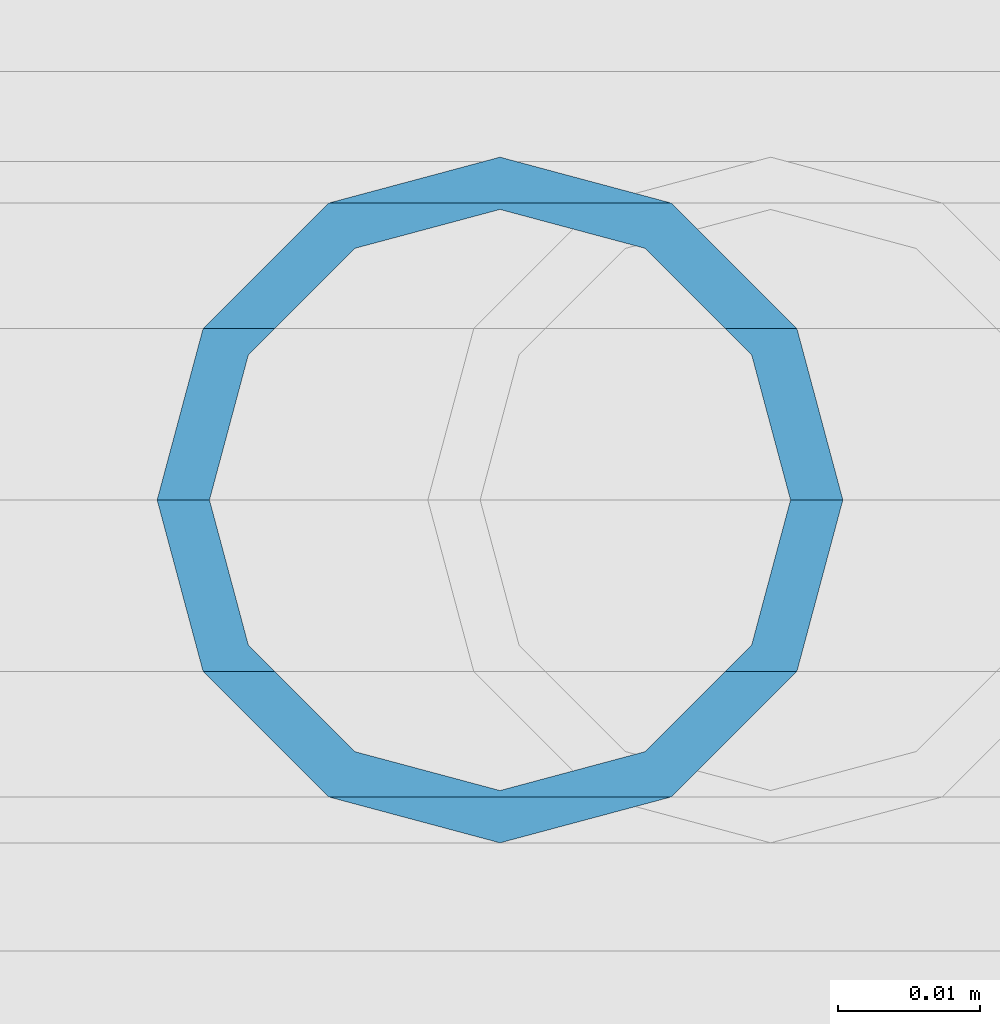
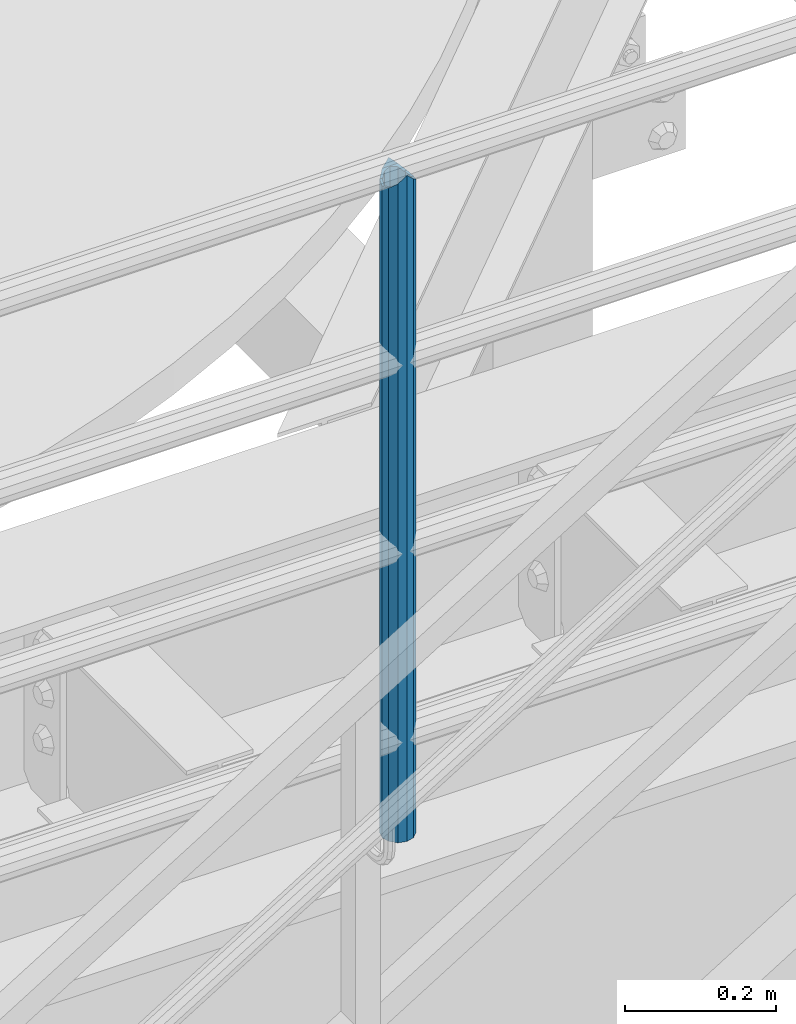
# One storey, part 637 of 1876: 1 column, 1 element without a shape of its own.
"""IFC2X3 building model written with IfcOpenShell, lengths in millimetres."""

from ifc_helpers import new_model, si_unit, frame, origin_with_axes, place, context, subcontext, project, spatial, faceted_brep, material, type_object, element, aggregate, save


model = new_model("IFC2X3")

# Units and contexts
model_context = context("Model", 3, precision=1e-05, world=origin_with_axes())
body_context = subcontext(model_context, "Body", "Model", "MODEL_VIEW")
ifc_project = project(units=[si_unit("LENGTHUNIT", "METRE", prefix="MILLI"), si_unit("AREAUNIT", "SQUARE_METRE"), si_unit("VOLUMEUNIT", "CUBIC_METRE"), si_unit("MASSUNIT", "GRAM", prefix="KILO"), si_unit("TIMEUNIT", "SECOND"), si_unit("PLANEANGLEUNIT", "RADIAN"), si_unit("SOLIDANGLEUNIT", "STERADIAN"), si_unit("THERMODYNAMICTEMPERATUREUNIT", "DEGREE_CELSIUS"), si_unit("LUMINOUSINTENSITYUNIT", "LUMEN")], contexts=[model_context])

# Site, building, storey
site_placement = place(None, origin_with_axes())
site = spatial("IfcSite", under=ifc_project, at=site_placement, CompositionType="ELEMENT")
building_placement = place(site_placement, origin_with_axes())
building = spatial("IfcBuilding", under=site, at=building_placement, Name="Undefined", CompositionType="ELEMENT")
storey_placement = place(building_placement, origin_with_axes())
storey = spatial("IfcBuildingStorey", under=building, at=storey_placement, Name="Undefined", CompositionType="ELEMENT", Elevation=0.0)

# Assembly, column
assembly_placement = place(storey_placement, origin_with_axes())
assembly = element("IfcElementAssembly", 1, at=assembly_placement, inside=storey, Name="RAIL", AssemblyPlace="NOTDEFINED", PredefinedType="RIGID_FRAME")
ifc_material = material()
column_type = type_object("IfcColumnType", Name="PIPE1-1/2SCH40", PredefinedType="NOTDEFINED")
column_placement = place(assembly_placement, frame((5048.24999996468, -4654.55000114554, 13309.6), z_axis=(0.0, 1.0, 0.0), x_axis=(0.0, 0.0, 1.0)))
column = element("IfcColumn", 2, at=column_placement, type_object=column_type, material=ifc_material, Name="POST", ObjectType="PIPE1-1/2SCH40", context=body_context, shape_type="Brep", body=[
    faceted_brep([(1076.325, 0.0, -24.1300000000001), (1064.26, 12.065, -20.8971929933186), (1064.26, -12.0650000000001, -20.8971929933186), (1054.93437856882, 17.7076214311801, 10.2235000000001), (1052.195, 20.4470000000001, 0.0), (1052.195, 24.13, 0.0), (1055.42780700668, 20.8971929933185, 12.0649999999996), (1055.42780700668, 15.8661214311869, 12.0649999999932), (1055.42780700668, 15.8661214311742, -12.065000000006), (1055.42780700668, 20.8971929933185, -12.0649999999996), (1054.93437856882, 17.7076214311801, -10.2235000000001), (1061.07042843786, 10.2235000000001, -17.7076214311801), (1063.80980700668, 0.0, -20.4470000000001), (1061.07042843786, -10.2235000000001, -17.7076214311801), (1055.42780700668, -15.8661214311742, -12.065000000006), (1055.42780700668, -20.8971929933184, -12.0649999999996), (1054.93437856882, -17.7076214311801, -10.2235000000001), (1052.195, -20.4470000000001, 0.0), (1052.195, -24.1300000000001, 0.0), (1054.93437856882, -17.7076214311801, 10.2235000000001), (1055.42780700668, -15.8661214311869, 12.0649999999932), (1055.42780700668, -20.8971929933184, 12.0649999999996), (1076.325, 0.0, 24.1300000000001), (1064.26, -12.0650000000001, 20.8971929933186), (1064.26, 12.065, 20.8971929933186), (1061.07042843787, -10.2235000000001, 17.7076214311801), (1063.80980700669, 0.0, 20.4470000000001), (1061.07042843787, 10.2235000000001, 17.7076214311801), (0.0, -20.8971929933184, -12.0649999999996), (0.0, -12.0650000000001, -20.8971929933186), (-1.45519152283669e-11, 0.0, -24.130000000001), (0.0, 12.0650000000001, -20.8971929933186), (0.0, 20.8971929933184, -12.0649999999996), (0.0, 24.1299999999992, 0.0), (0.0, 20.8971929933184, 12.0649999999996), (0.0, 12.0650000000001, 20.8971929933186), (-1.45519152283669e-11, 0.0, 24.130000000001), (0.0, -20.8971929933184, 12.0649999999996), (0.0, -24.1299999999992, 0.0), (0.0, -12.0650000000001, 20.8971929933186), (0.0, -17.7076214311803, -10.2235000000001), (0.0, -10.2235000000001, -17.7076214311801), (-1.45519152283669e-11, 0.0, -20.4470000000001), (0.0, 10.2235000000001, -17.7076214311801), (0.0, 17.7076214311803, -10.2235000000001), (0.0, 20.4469999999999, 0.0), (0.0, 17.7076214311803, 10.2235000000001), (0.0, 10.2235000000001, 17.7076214311801), (-1.45519152283669e-11, 0.0, 20.4470000000001), (0.0, -10.2235000000001, 17.7076214311801), (0.0, -17.7076214311803, 10.2235000000001), (0.0, -20.4469999999999, 0.0)], [[[0, 1, 2]], [[3, 4, 5, 6, 7]], [[8, 9, 5, 4, 10]], [[2, 1, 9, 8, 11, 12, 13, 14, 15]], [[15, 14, 16, 17, 18]], [[18, 17, 19, 20, 21]], [[22, 23, 24]], [[21, 20, 25, 26, 27, 7, 6, 24, 23]], [[28, 29, 2, 15]], [[29, 30, 0, 2]], [[30, 31, 1, 0]], [[31, 32, 9, 1]], [[32, 33, 5, 9]], [[33, 34, 6, 5]], [[34, 35, 24, 6]], [[35, 36, 22, 24]], [[37, 38, 18, 21]], [[39, 37, 21, 23]], [[36, 39, 23, 22]], [[38, 28, 15, 18]], [[37, 39, 36, 35, 34, 33, 32, 31, 30, 29, 28, 38], [40, 41, 42, 43, 44, 45, 46, 47, 48, 49, 50, 51]], [[49, 48, 26, 25]], [[19, 50, 49, 25, 20]], [[51, 50, 19, 17]], [[40, 51, 17, 16]], [[41, 40, 16, 14, 13]], [[42, 41, 13, 12]], [[43, 42, 12, 11]], [[10, 44, 43, 11, 8]], [[45, 44, 10, 4]], [[46, 45, 4, 3]], [[47, 46, 3, 7, 27]], [[48, 47, 27, 26]]]),
])
aggregate(assembly, [column])

save(model, "model.ifc")
